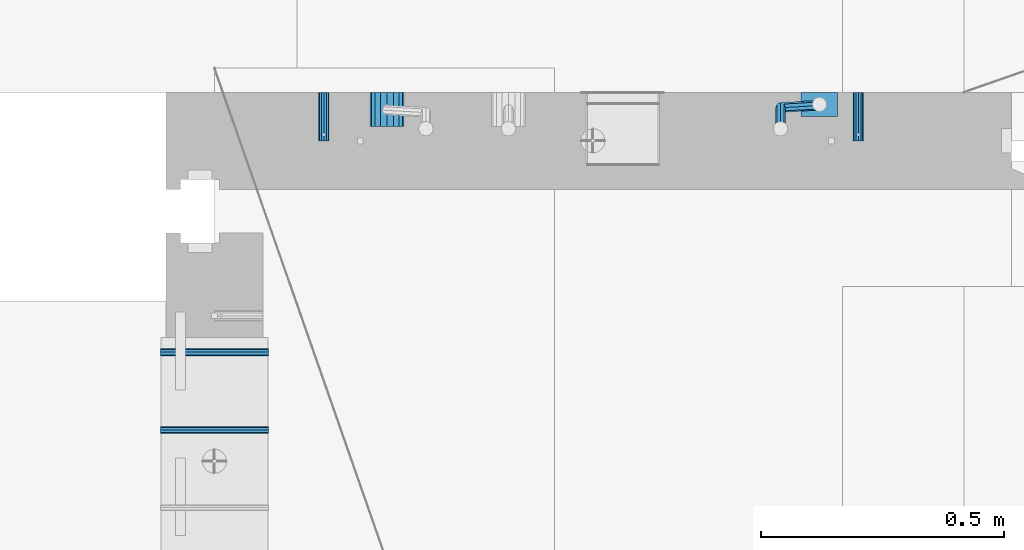
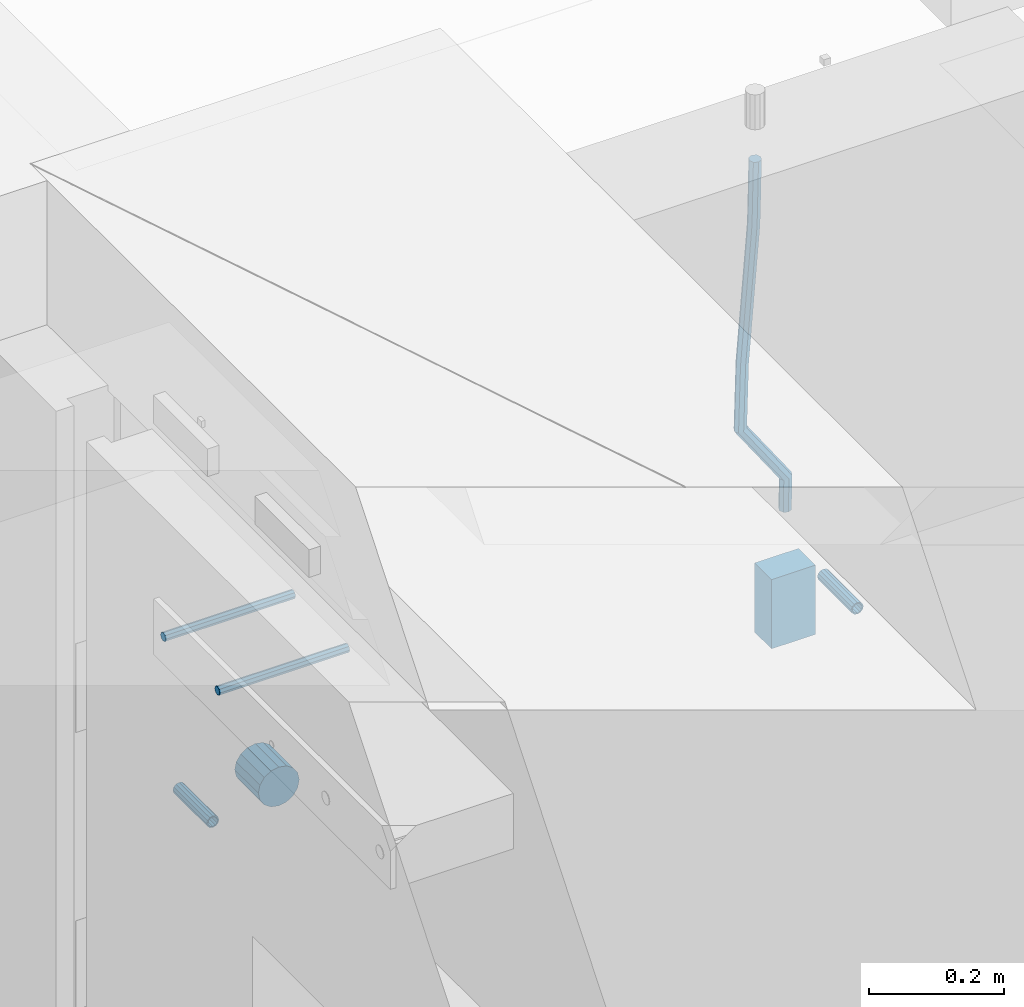
# One storey, part 138 of 309: 7 beams, 4 elements without a shape of their own.
"""IFC2X3 building model written with IfcOpenShell, lengths in millimetres."""

from ifc_helpers import new_model, si_unit, frame, origin_with_axes, place, context, subcontext, project, spatial, faceted_brep, material, type_object, element, aggregate, save


model = new_model("IFC2X3")

# Units and contexts
model_context = context("Model", 3, precision=1e-05, world=origin_with_axes())
body_context = subcontext(model_context, "Body", "Model", "MODEL_VIEW")
ifc_project = project(units=[si_unit("LENGTHUNIT", "METRE", prefix="MILLI"), si_unit("AREAUNIT", "SQUARE_METRE"), si_unit("VOLUMEUNIT", "CUBIC_METRE"), si_unit("MASSUNIT", "GRAM", prefix="KILO"), si_unit("TIMEUNIT", "SECOND"), si_unit("PLANEANGLEUNIT", "RADIAN"), si_unit("SOLIDANGLEUNIT", "STERADIAN"), si_unit("THERMODYNAMICTEMPERATUREUNIT", "DEGREE_CELSIUS"), si_unit("LUMINOUSINTENSITYUNIT", "LUMEN")], contexts=[model_context])

# Site, building, storey
site_placement = place(None, origin_with_axes())
site = spatial("IfcSite", under=ifc_project, at=site_placement, CompositionType="ELEMENT")
building_placement = place(site_placement, origin_with_axes())
building = spatial("IfcBuilding", under=site, at=building_placement, CompositionType="ELEMENT")
storey_placement = place(building_placement, origin_with_axes())
storey = spatial("IfcBuildingStorey", under=building, at=storey_placement, Name="7", CompositionType="ELEMENT", Elevation=0.0)

# Assemblies, beams
assembly_1_placement = place(storey_placement, origin_with_axes())
assembly_1 = element("IfcElementAssembly", 1, at=assembly_1_placement, inside=storey, AssemblyPlace="NOTDEFINED", PredefinedType="REINFORCEMENT_UNIT")
assembly_2_placement = place(assembly_1_placement, origin_with_axes())
assembly_2 = element("IfcElementAssembly", 2, at=assembly_2_placement, Name="Steel Assembly", AssemblyPlace="NOTDEFINED", PredefinedType="RIGID_FRAME")
ifc_material_1 = material(Name="STEEL/Steel_Undefined")
beam_type_1 = type_object("IfcBeamType", PredefinedType="NOTDEFINED")
beam_1_placement = place(assembly_2_placement, frame((27934.9999668009, 17080.0, 101555.0), z_axis=(1.0, 0.0, 0.0), x_axis=(0.0, -1.0, 0.0)))
beam_1 = element("IfcBeam", 3, at=beam_1_placement, type_object=beam_type_1, material=ifc_material_1, Name="M16", context=body_context, shape_type="Brep", body=[
    faceted_brep([(0.0, -8.49999999999272, -1.45519152283669e-11), (0.0, -7.36121593215648, 4.24999999998545), (100.000000000262, -7.36121593215648, 4.24999999998545), (100.000000000262, -8.49999999999272, -1.45519152283669e-11), (0.0, -4.24999999998545, 7.36121593216376), (100.000000000262, -4.24999999998545, 7.36121593216376), (0.0, 1.45519152283669e-11, 8.49999999998545), (100.000000000262, 1.45519152283669e-11, 8.49999999998545), (0.0, 4.25000000001455, 7.36121593216376), (100.000000000262, 4.25000000001455, 7.36121593216376), (0.0, 7.36121593217104, 4.24999999998545), (100.000000000262, 7.36121593217104, 4.24999999998545), (0.0, 8.50000000000728, 0.0), (100.000000000262, 8.50000000000728, 0.0), (0.0, 7.36121593217104, -4.25000000001455), (100.000000000262, 7.36121593217104, -4.25000000001455), (0.0, 4.25000000000728, -7.36121593219286), (100.000000000262, 4.25000000000728, -7.36121593219286), (0.0, 7.27595761418343e-12, -8.5), (100.000000000262, 7.27595761418343e-12, -8.5), (0.0, -4.24999999999272, -7.36121593217831), (100.000000000262, -4.24999999999272, -7.36121593217831), (0.0, -7.36121593215648, -4.25), (100.000000000262, -7.36121593215648, -4.25), (0.0, -10.4999999999927, -1.45519152283669e-11), (0.0, -9.09326673972828, -5.25000000001455), (100.000000000262, -9.09326673972828, -5.25000000001455), (100.000000000262, -10.4999999999927, -1.45519152283669e-11), (0.0, -5.24999999998545, -9.09326673974283), (100.000000000262, -5.24999999998545, -9.09326673974283), (0.0, 7.27595761418343e-12, -10.5), (100.000000000262, 7.27595761418343e-12, -10.5), (0.0, 5.25000000001455, -9.09326673975738), (100.000000000262, 5.25000000001455, -9.09326673975738), (0.0, 9.09326673975011, -5.25000000001455), (100.000000000262, 9.09326673975011, -5.25000000001455), (0.0, 10.5000000000073, -1.45519152283669e-11), (100.000000000262, 10.5000000000073, -1.45519152283669e-11), (0.0, 9.09326673975011, 5.25), (100.000000000262, 9.09326673975011, 5.25), (0.0, 5.25000000000728, 9.09326673972828), (100.000000000262, 5.25000000000728, 9.09326673972828), (0.0, 1.45519152283669e-11, 10.4999999999854), (100.000000000262, 1.45519152283669e-11, 10.4999999999854), (0.0, -5.24999999999272, 9.09326673972828), (100.000000000262, -5.24999999999272, 9.09326673972828), (0.0, -9.09326673972828, 5.24999999998545), (100.000000000262, -9.09326673972828, 5.24999999998545)], [[[0, 1, 2, 3]], [[1, 4, 5, 2]], [[4, 6, 7, 5]], [[6, 8, 9, 7]], [[8, 10, 11, 9]], [[10, 12, 13, 11]], [[12, 14, 15, 13]], [[14, 16, 17, 15]], [[16, 18, 19, 17]], [[18, 20, 21, 19]], [[20, 22, 23, 21]], [[22, 0, 3, 23]], [[24, 25, 26, 27]], [[25, 28, 29, 26]], [[28, 30, 31, 29]], [[30, 32, 33, 31]], [[32, 34, 35, 33]], [[34, 36, 37, 35]], [[36, 38, 39, 37]], [[38, 40, 41, 39]], [[40, 42, 43, 41]], [[42, 44, 45, 43]], [[44, 46, 47, 45]], [[46, 24, 27, 47]], [[29, 31, 33, 35, 37, 39, 41, 43, 45, 47, 27, 26], [5, 7, 9, 11, 13, 15, 17, 19, 21, 23, 3, 2]], [[46, 44, 42, 40, 38, 36, 34, 32, 30, 28, 25, 24], [22, 20, 18, 16, 14, 12, 10, 8, 6, 4, 1, 0]]]),
])
aggregate(assembly_2, [beam_1])
assembly_3_placement = place(assembly_1_placement, origin_with_axes())
assembly_3 = element("IfcElementAssembly", 4, at=assembly_3_placement, Name="Steel Assembly", AssemblyPlace="NOTDEFINED", PredefinedType="RIGID_FRAME")
beam_2_placement = place(assembly_3_placement, frame((26834.9999668009, 17080.0, 101555.0), z_axis=(-1.0, 3.00000001838171e-08, 0.0), x_axis=(0.0, -1.0, 0.0)))
beam_2 = element("IfcBeam", 5, at=beam_2_placement, type_object=beam_type_1, material=ifc_material_1, Name="M16", context=body_context, shape_type="Brep", body=[
    faceted_brep([(0.0, -8.49999999999272, -1.45519152283669e-11), (0.0, -7.36121593215648, 4.24999999998545), (100.000000000262, -7.36121593215648, 4.24999999998545), (100.000000000262, -8.49999999999272, -1.45519152283669e-11), (0.0, -4.24999999998545, 7.36121593216376), (100.000000000262, -4.24999999998545, 7.36121593216376), (0.0, 1.45519152283669e-11, 8.49999999998545), (100.000000000262, 1.45519152283669e-11, 8.49999999998545), (0.0, 4.25000000001455, 7.36121593216376), (100.000000000262, 4.25000000001455, 7.36121593216376), (0.0, 7.36121593217104, 4.24999999998545), (100.000000000262, 7.36121593217104, 4.24999999998545), (0.0, 8.50000000000728, 0.0), (100.000000000262, 8.50000000000728, 0.0), (0.0, 7.36121593217104, -4.25000000001455), (100.000000000262, 7.36121593217104, -4.25000000001455), (0.0, 4.25000000000728, -7.36121593219286), (100.000000000262, 4.25000000000728, -7.36121593219286), (0.0, 7.27595761418343e-12, -8.5), (100.000000000262, 7.27595761418343e-12, -8.5), (0.0, -4.24999999999272, -7.36121593217831), (100.000000000262, -4.24999999999272, -7.36121593217831), (0.0, -7.36121593215648, -4.25), (100.000000000262, -7.36121593215648, -4.25), (0.0, -10.4999999999927, -1.45519152283669e-11), (0.0, -9.09326673972828, -5.25000000001455), (100.000000000262, -9.09326673972828, -5.25000000001455), (100.000000000262, -10.4999999999927, -1.45519152283669e-11), (0.0, -5.24999999998545, -9.09326673974283), (100.000000000262, -5.24999999998545, -9.09326673974283), (0.0, 7.27595761418343e-12, -10.5), (100.000000000262, 7.27595761418343e-12, -10.5), (0.0, 5.25000000001455, -9.09326673975738), (100.000000000262, 5.25000000001455, -9.09326673975738), (0.0, 9.09326673975011, -5.25000000001455), (100.000000000262, 9.09326673975011, -5.25000000001455), (0.0, 10.5000000000073, -1.45519152283669e-11), (100.000000000262, 10.5000000000073, -1.45519152283669e-11), (0.0, 9.09326673975011, 5.25), (100.000000000262, 9.09326673975011, 5.25), (0.0, 5.25000000000728, 9.09326673972828), (100.000000000262, 5.25000000000728, 9.09326673972828), (0.0, 1.45519152283669e-11, 10.4999999999854), (100.000000000262, 1.45519152283669e-11, 10.4999999999854), (0.0, -5.24999999999272, 9.09326673972828), (100.000000000262, -5.24999999999272, 9.09326673972828), (0.0, -9.09326673972828, 5.24999999998545), (100.000000000262, -9.09326673972828, 5.24999999998545)], [[[0, 1, 2, 3]], [[1, 4, 5, 2]], [[4, 6, 7, 5]], [[6, 8, 9, 7]], [[8, 10, 11, 9]], [[10, 12, 13, 11]], [[12, 14, 15, 13]], [[14, 16, 17, 15]], [[16, 18, 19, 17]], [[18, 20, 21, 19]], [[20, 22, 23, 21]], [[22, 0, 3, 23]], [[24, 25, 26, 27]], [[25, 28, 29, 26]], [[28, 30, 31, 29]], [[30, 32, 33, 31]], [[32, 34, 35, 33]], [[34, 36, 37, 35]], [[36, 38, 39, 37]], [[38, 40, 41, 39]], [[40, 42, 43, 41]], [[42, 44, 45, 43]], [[44, 46, 47, 45]], [[46, 24, 27, 47]], [[29, 31, 33, 35, 37, 39, 41, 43, 45, 47, 27, 26], [5, 7, 9, 11, 13, 15, 17, 19, 21, 23, 3, 2]], [[46, 44, 42, 40, 38, 36, 34, 32, 30, 28, 25, 24], [22, 20, 18, 16, 14, 12, 10, 8, 6, 4, 1, 0]]]),
])
aggregate(assembly_3, [beam_2])
ifc_material_2 = material()
beam_type_2 = type_object("IfcBeamType", Name="D20", PredefinedType="NOTDEFINED")
beam_3_placement = place(assembly_1_placement, frame((27854.9999105249, 17055.0000022791, 101717.5), z_axis=(0.00020576299992186, -0.999642804629538, -0.0267249099901004), x_axis=(-4.30000201928125e-08, -0.0267249099948059, 0.999642825806181)))
beam_3 = element("IfcBeam", 6, at=beam_3_placement, type_object=beam_type_2, material=ifc_material_2, Name="JM20", ObjectType="D20", context=body_context, shape_type="Brep", body=[
    faceted_brep([(0.0, -10.0, 0.0), (-4.19531716033816e-08, -7.07106781186667, -7.07106781187031), (57.3778003524785, -7.07106779628884, -7.0710678060168), (57.3778003565822, -9.99999998442945, 5.84986992180347e-09), (0.0, 0.0, -10.0), (57.3778003491898, 1.55741872731596e-08, -9.99999999415013), (4.196772351861e-08, 7.07106781186303, -7.07106781186667), (57.3778003486368, 7.07106782744086, -7.0710678060168), (0.0, 10.0, 0.0), (57.3778003511543, 10.0000000155705, 5.84986992180347e-09), (4.196772351861e-08, 7.07106781185939, 7.07106781185939), (57.3778003552725, 7.07106782744086, 7.0710678177129), (0.0, 0.0, 10.0), (57.3778003585467, 1.55741872731596e-08, 10.0000000058535), (-4.19531716033816e-08, -7.07106781187031, 7.07106781185939), (57.3778003591142, -7.07106779628884, 7.0710678177129), (63.2348501311644, -7.07106779493188, -7.07106780540926), (64.1057957623998, -9.99999998283238, 6.54472387395799e-09), (61.04994790192, 1.63490767590702e-08, -9.99999999377178), (58.8309751681372, 7.07106782761548, -7.07106780586037), (57.8777760627127, 10.0000000155014, 5.90807758271694e-09), (58.7487216939626, 7.07106782759729, 7.07106781786206), (60.9336239231925, 1.63163349498063e-08, 10.0000000062173), (63.1525966569752, -7.07106779495371, 7.07106781830953), (68.0560815638019, -3.74583294561307, -7.00896065082998), (69.6439432500047, -6.18030344188082, 0.0713424813729944), (64.0726841869619, 2.08480100043016, -9.96106107280502), (60.0271712784888, 7.89609210789058, -7.05565839484916), (58.2893494334276, 10.283864860914, 0.00530189843993867), (59.8772111196158, 7.84939436464629, 7.08560503063927), (63.8606084964704, 2.01876041860305, 10.037705452618), (67.9061214049289, -3.79253068885737, 7.13230277466573), (178.098456601496, 72.1511127806843, -5.59139360533663), (179.686318287684, 69.716642284413, 1.48890952685906), (174.115059224641, 77.9817467267239, -8.54349402731532), (170.069546316168, 83.7930378341844, -5.63809134935946), (168.331724471092, 86.1808105872078, 1.42286894392964), (169.91958615731, 83.7463400909437, 8.50317207612898), (173.90298353415, 77.9157061448968, 11.455272498104), (177.948496442623, 72.1044150374437, 8.5498698201518), (179.289255982527, 72.9724149014583, -5.57605371504542), (180.097891658399, 70.0005071298292, 1.4942114193982), (177.129995245661, 80.0611678177193, -8.50465558942597), (174.884975102759, 87.1142705605816, -5.5760589445199), (173.869297905752, 90.00011120009, 1.49420402380565), (174.67793358161, 87.0282034284573, 8.5644691582529), (176.837194318476, 79.9394505121963, 11.4930710326298), (179.082214461378, 72.8863477693376, 8.56447438772739), (180.735622590379, 72.972420835973, -5.54778204405011), (180.597796167538, 70.0005091809617, 1.50398289485383), (180.791991426609, 80.0611828430738, -8.4330757073476), (180.733882576489, 87.1142945589418, -5.46173219850607), (180.595335416292, 90.0001387973534, 1.62567575346111), (180.457508993451, 87.0282271423457, 8.67744069236505), (180.401140157206, 79.939465135245, 11.5627343556625), (180.459249007356, 72.8863534193733, 8.59139084682101), (299.223827734662, 72.9729069989553, -3.23173054285144), (299.086001311836, 70.0009953439476, 3.82003439605251), (299.280196570893, 80.0616690060597, -6.11702420615256), (299.222087720773, 87.1147807219277, -3.14568069731467), (299.083540560576, 90.0006249603393, 3.94172725465251), (298.945714137735, 87.0287133053316, 10.9934921935564), (298.889345301504, 79.9399512982272, 13.8787858568576), (298.947454151639, 72.8868395823556, 10.9074423480197), (300.386274806908, 72.9729117685347, -3.20900855728542), (299.975441269635, 70.0009989933678, 3.8374199978316), (300.554299891708, 80.0616742337661, -6.09211971118202), (300.381089708186, 87.1147854773699, -3.12302605173682), (299.968108432717, 90.0006285897653, 3.95901762330686), (299.557274895458, 87.0287158145948, 11.0054461784239), (299.389249810658, 79.9399533493597, 13.8885573323169), (299.562459994166, 72.8868421057559, 10.9194636728716), (301.54348499664, 72.972935138263, -3.09647384826167), (300.860874255726, 70.0010168745794, 3.92352530897551), (301.822663312996, 80.0616998482183, -5.96877573286474), (301.534870333402, 87.1148087778347, -3.01082485606094), (300.848691282124, 90.0006463730351, 4.04465127535514), (300.166080541225, 87.0287281093551, 11.0646504325923), (299.886902224855, 79.9399633993926, 13.9369523171918), (300.174695204449, 72.8868544697798, 10.9790014403879), (567.277632096637, 72.9783016087349, 22.7452575737989), (566.595021355723, 70.0063833450513, 29.7652567310361), (567.556810412992, 80.0670663186975, 19.8729556891958), (567.269017433413, 87.1201752483139, 22.8309065659996), (566.582838382135, 90.0060128435071, 29.886382697412), (565.900227641221, 87.0340945798234, 36.9063818546456), (565.621049324851, 79.9453298698681, 39.7786837392523), (565.90884230446, 72.8922209402554, 36.8207328624449), (567.849310941645, 72.9783131537188, 22.8008513743443), (567.441064932689, 70.0064004308078, 29.8475315576834), (568.054462827218, 80.0670763687303, 19.9213506740707), (567.93634539716, 87.1201887249226, 22.8958019142228), (567.564150240039, 90.0060326609891, 29.9818118989315), (567.155904231084, 87.0341199380709, 37.0284920822669), (566.950752345525, 79.9453567230667, 39.9079927825405), (567.068869775569, 72.8922443668707, 36.9335415423957), (568.423586898687, 72.9708243880268, 22.8084944200891), (568.290952048657, 69.9953175961527, 29.8588427157192), (568.554376054599, 80.0605573198627, 19.9280040253361), (568.606705002705, 87.1114469937784, 22.9047237384184), (568.549920154881, 89.9931778656028, 29.9949315228005), (568.417285304851, 87.0176710737251, 37.0452798184269), (568.286496148939, 79.9279381418964, 39.9257702131799), (568.234167200833, 72.8770484679771, 36.9490505000977), (589.912124239258, 72.6906061074042, 23.0944856267633), (589.779489389242, 69.7150993155265, 30.1448339223862), (590.042913395198, 79.7803390392328, 20.2139952320067), (590.095242343275, 86.8312287131521, 23.190714945089), (590.038457495451, 89.7129595849765, 30.2809227294711), (589.905822645451, 86.7374527930988, 37.3312710250975), (589.775033489525, 79.6477198612702, 40.2117614198505), (589.722704541418, 72.5968301873472, 37.2350417067682), (590.547165551296, 72.6823249395493, 23.1029373993588), (590.439554471668, 69.7064918286778, 30.1536187366546), (590.620682129796, 79.7728047264573, 20.2216847631717), (590.617039192599, 86.8244242939545, 23.197659545749), (590.538370722847, 89.7064405361089, 30.2875760807365), (590.430759643248, 86.7306074252338, 37.3382574180287), (590.357243064718, 79.6401276383258, 40.2195100542194), (590.36088600193, 72.5885080708285, 37.243535271642), (591.182260594243, 72.6841934809891, 23.1112002334121), (591.099675200006, 69.7084600799535, 30.1622167658497), (591.198500084778, 79.7744922147613, 20.2291794306657), (591.138880798317, 86.8259554442993, 23.2044030568104), (591.038326904265, 89.7079316443269, 30.2940254627501), (590.955741510043, 86.7321982432914, 37.3450419951805), (590.939502019522, 79.6418995095191, 40.2270627979342), (590.999121305984, 72.5904362799774, 37.2518391717822), (691.203058405095, 72.9824563748625, 24.4085746238379), (691.120473010888, 70.0067229738306, 31.4595911562756), (691.219297895645, 80.0727551086347, 21.5265538210951), (691.159678609169, 87.1242183381728, 24.5017774472362), (691.059124715146, 90.0061945381967, 31.591399853176), (690.976539320895, 87.0304611371721, 38.6424163856136), (690.960299830374, 79.9401624033926, 41.5244371883564), (691.019919116836, 72.8886991738545, 38.5492135622153)], [[[0, 1, 2, 3]], [[1, 4, 5, 2]], [[4, 6, 7, 5]], [[6, 8, 9, 7]], [[8, 10, 11, 9]], [[10, 12, 13, 11]], [[12, 14, 15, 13]], [[14, 0, 3, 15]], [[14, 12, 10, 8, 6, 4, 1, 0]], [[3, 2, 16, 17]], [[2, 5, 18, 16]], [[5, 7, 19, 18]], [[7, 9, 20, 19]], [[9, 11, 21, 20]], [[11, 13, 22, 21]], [[13, 15, 23, 22]], [[15, 3, 17, 23]], [[17, 16, 24, 25]], [[16, 18, 26, 24]], [[18, 19, 27, 26]], [[19, 20, 28, 27]], [[20, 21, 29, 28]], [[21, 22, 30, 29]], [[22, 23, 31, 30]], [[23, 17, 25, 31]], [[25, 24, 32, 33]], [[24, 26, 34, 32]], [[26, 27, 35, 34]], [[27, 28, 36, 35]], [[28, 29, 37, 36]], [[29, 30, 38, 37]], [[30, 31, 39, 38]], [[31, 25, 33, 39]], [[33, 32, 40, 41]], [[32, 34, 42, 40]], [[34, 35, 43, 42]], [[35, 36, 44, 43]], [[36, 37, 45, 44]], [[37, 38, 46, 45]], [[38, 39, 47, 46]], [[39, 33, 41, 47]], [[41, 40, 48, 49]], [[40, 42, 50, 48]], [[42, 43, 51, 50]], [[43, 44, 52, 51]], [[44, 45, 53, 52]], [[45, 46, 54, 53]], [[46, 47, 55, 54]], [[47, 41, 49, 55]], [[49, 48, 56, 57]], [[48, 50, 58, 56]], [[50, 51, 59, 58]], [[51, 52, 60, 59]], [[52, 53, 61, 60]], [[53, 54, 62, 61]], [[54, 55, 63, 62]], [[55, 49, 57, 63]], [[57, 56, 64, 65]], [[56, 58, 66, 64]], [[58, 59, 67, 66]], [[59, 60, 68, 67]], [[60, 61, 69, 68]], [[61, 62, 70, 69]], [[62, 63, 71, 70]], [[63, 57, 65, 71]], [[65, 64, 72, 73]], [[64, 66, 74, 72]], [[66, 67, 75, 74]], [[67, 68, 76, 75]], [[68, 69, 77, 76]], [[69, 70, 78, 77]], [[70, 71, 79, 78]], [[71, 65, 73, 79]], [[73, 72, 80, 81]], [[72, 74, 82, 80]], [[74, 75, 83, 82]], [[75, 76, 84, 83]], [[76, 77, 85, 84]], [[77, 78, 86, 85]], [[78, 79, 87, 86]], [[79, 73, 81, 87]], [[81, 80, 88, 89]], [[80, 82, 90, 88]], [[82, 83, 91, 90]], [[83, 84, 92, 91]], [[84, 85, 93, 92]], [[85, 86, 94, 93]], [[86, 87, 95, 94]], [[87, 81, 89, 95]], [[89, 88, 96, 97]], [[88, 90, 98, 96]], [[90, 91, 99, 98]], [[91, 92, 100, 99]], [[92, 93, 101, 100]], [[93, 94, 102, 101]], [[94, 95, 103, 102]], [[95, 89, 97, 103]], [[97, 96, 104, 105]], [[96, 98, 106, 104]], [[98, 99, 107, 106]], [[99, 100, 108, 107]], [[100, 101, 109, 108]], [[101, 102, 110, 109]], [[102, 103, 111, 110]], [[103, 97, 105, 111]], [[105, 104, 112, 113]], [[104, 106, 114, 112]], [[106, 107, 115, 114]], [[107, 108, 116, 115]], [[108, 109, 117, 116]], [[109, 110, 118, 117]], [[110, 111, 119, 118]], [[111, 105, 113, 119]], [[113, 112, 120, 121]], [[112, 114, 122, 120]], [[114, 115, 123, 122]], [[115, 116, 124, 123]], [[116, 117, 125, 124]], [[117, 118, 126, 125]], [[118, 119, 127, 126]], [[119, 113, 121, 127]], [[121, 120, 128, 129]], [[120, 122, 130, 128]], [[122, 123, 131, 130]], [[123, 124, 132, 131]], [[124, 125, 133, 132]], [[125, 126, 134, 133]], [[126, 127, 135, 134]], [[127, 121, 129, 135]], [[130, 131, 132, 133, 134, 135, 129, 128]]]),
])
beam_type_3 = type_object("IfcBeamType", Name="D70", PredefinedType="NOTDEFINED")
beam_4_placement = place(assembly_1_placement, frame((26964.9999105288, 17080.0000022791, 101555.0), z_axis=(0.0, 0.0, 1.0), x_axis=(0.0, -1.0, 0.0)))
beam_4 = element("IfcBeam", 7, at=beam_4_placement, type_object=beam_type_3, material=ifc_material_2, ObjectType="D70", context=body_context, shape_type="Brep", body=[
    faceted_brep([(0.0, -35.0, 0.0), (0.0, -32.3357836378964, -13.3939201327739), (70.0, -32.3357836378964, -13.3939201327739), (70.0, -35.0, 0.0), (0.0, -24.7487373415279, -24.7487373415352), (70.0, -24.7487373415279, -24.7487373415352), (0.0, -13.3939201327776, -32.3357836379), (70.0, -13.3939201327776, -32.3357836379), (0.0, 0.0, -35.0), (70.0, 0.0, -35.0), (0.0, 13.3939201327776, -32.3357836379), (70.0, 13.3939201327776, -32.3357836379), (0.0, 24.7487373415279, -24.7487373415352), (70.0, 24.7487373415279, -24.7487373415352), (0.0, 32.3357836378964, -13.3939201327739), (70.0, 32.3357836378964, -13.3939201327739), (0.0, 35.0, 0.0), (70.0, 35.0, 0.0), (0.0, 32.3357836378964, 13.3939201327739), (70.0, 32.3357836378964, 13.3939201327739), (0.0, 24.7487373415279, 24.7487373415352), (70.0, 24.7487373415279, 24.7487373415352), (0.0, 13.3939201327776, 32.3357836379), (70.0, 13.3939201327776, 32.3357836379), (0.0, 0.0, 35.0), (70.0, 0.0, 35.0), (0.0, -13.3939201327776, 32.3357836379), (70.0, -13.3939201327776, 32.3357836379), (0.0, -24.7487373415279, 24.7487373415352), (70.0, -24.7487373415279, 24.7487373415352), (0.0, -32.3357836378964, 13.3939201327739), (70.0, -32.3357836378964, 13.3939201327739)], [[[0, 1, 2, 3]], [[1, 4, 5, 2]], [[4, 6, 7, 5]], [[6, 8, 9, 7]], [[8, 10, 11, 9]], [[10, 12, 13, 11]], [[12, 14, 15, 13]], [[14, 16, 17, 15]], [[16, 18, 19, 17]], [[18, 20, 21, 19]], [[20, 22, 23, 21]], [[22, 24, 25, 23]], [[24, 26, 27, 25]], [[26, 28, 29, 27]], [[28, 30, 31, 29]], [[30, 0, 3, 31]], [[5, 7, 9, 11, 13, 15, 17, 19, 21, 23, 25, 27, 29, 31, 3, 2]], [[30, 28, 26, 24, 22, 20, 18, 16, 14, 12, 10, 8, 6, 4, 1, 0]]]),
])

# Assembly, beams
assembly_4_placement = place(storey_placement, origin_with_axes())
assembly_4 = element("IfcElementAssembly", 8, at=assembly_4_placement, inside=storey, AssemblyPlace="NOTDEFINED", PredefinedType="REINFORCEMENT_UNIT")
ifc_material_3 = material()
beam_type_4 = type_object("IfcBeamType", Name="D15", PredefinedType="NOTDEFINED")
beam_5_placement = place(assembly_4_placement, frame((26720.9994161083, 16544.9998474121, 102270.0), z_axis=(0.0, -1.0, 0.0), x_axis=(-1.0, 3.00000001838171e-08, 0.0)))
beam_5 = element("IfcBeam", 9, at=beam_5_placement, type_object=beam_type_4, material=ifc_material_3, Name="15", ObjectType="D15", context=body_context, shape_type="Brep", body=[
    faceted_brep([(0.0, -7.5, 0.0), (0.0, -5.30330085889727, -5.30330085890091), (222.000077784061, -5.30330085889727, -5.30330085890091), (222.000077784061, -7.5, 0.0), (0.0, 1.45519152283669e-11, -7.5), (222.000077784061, 0.0, -7.5), (0.0, 5.30330085889727, -5.30330085890091), (222.000077784061, 5.30330085889727, -5.30330085890091), (0.0, 7.5, 0.0), (222.000077784061, 7.5, 0.0), (0.0, 5.30330085889727, 5.30330085890091), (222.000077784061, 5.30330085889727, 5.30330085890091), (0.0, 1.45519152283669e-11, 7.5), (222.000077784061, 0.0, 7.5), (0.0, -5.30330085889727, 5.30330085890091), (222.000077784061, -5.30330085889727, 5.30330085890091)], [[[0, 1, 2, 3]], [[1, 4, 5, 2]], [[4, 6, 7, 5]], [[6, 8, 9, 7]], [[8, 10, 11, 9]], [[10, 12, 13, 11]], [[12, 14, 15, 13]], [[14, 0, 3, 15]], [[5, 7, 9, 11, 13, 15, 3, 2]], [[14, 12, 10, 8, 6, 4, 1, 0]]]),
])
beam_6_placement = place(assembly_4_placement, frame((26720.9994161083, 16385.0, 102270.0), z_axis=(0.0, -1.0, 0.0), x_axis=(-1.0, 3.00000001838171e-08, 0.0)))
beam_6 = element("IfcBeam", 10, at=beam_6_placement, type_object=beam_type_4, material=ifc_material_3, Name="15", ObjectType="D15", context=body_context, shape_type="Brep", body=[
    faceted_brep([(0.0, -7.5, 0.0), (0.0, -5.30330085889727, -5.30330085890091), (222.000077784061, -5.30330085889727, -5.30330085890091), (222.000077784061, -7.5, 0.0), (0.0, 1.45519152283669e-11, -7.5), (222.000077784061, 0.0, -7.5), (0.0, 5.30330085889727, -5.30330085890091), (222.000077784061, 5.30330085889727, -5.30330085890091), (0.0, 7.5, 0.0), (222.000077784061, 7.5, 0.0), (0.0, 5.30330085889727, 5.30330085890091), (222.000077784061, 5.30330085889727, 5.30330085890091), (0.0, 1.45519152283669e-11, 7.5), (222.000077784061, 0.0, 7.5), (0.0, -5.30330085889727, 5.30330085890091), (222.000077784061, -5.30330085889727, 5.30330085890091)], [[[0, 1, 2, 3]], [[1, 4, 5, 2]], [[4, 6, 7, 5]], [[6, 8, 9, 7]], [[8, 10, 11, 9]], [[10, 12, 13, 11]], [[12, 14, 15, 13]], [[14, 0, 3, 15]], [[5, 7, 9, 11, 13, 15, 3, 2]], [[14, 12, 10, 8, 6, 4, 1, 0]]]),
])
aggregate(assembly_4, [beam_5, beam_6])

# Beam
beam_type_5 = type_object("IfcBeamType", PredefinedType="NOTDEFINED")
beam_7_placement = place(assembly_1_placement, frame((27892.4999105288, 17055.0, 101555.0), z_axis=(0.0, 0.0, 1.0), x_axis=(-1.0, 3.00000001838171e-08, 0.0)))
beam_7 = element("IfcBeam", 11, at=beam_7_placement, type_object=beam_type_5, material=ifc_material_2, Name="WM1", context=body_context, shape_type="Brep", body=[
    faceted_brep([(0.0, 25.0, -62.5), (0.0, 25.0, 62.5), (75.0, 25.0, 62.5), (75.0, 25.0, -62.5), (0.0, -25.0, 62.5), (75.0, -25.0, 62.5), (0.0, -25.0, -62.5), (75.0, -25.0, -62.5)], [[[0, 1, 2, 3]], [[1, 4, 5, 2]], [[4, 6, 7, 5]], [[6, 0, 3, 7]], [[5, 7, 3, 2]], [[0, 6, 4, 1]]]),
])

aggregate(assembly_1, [assembly_2, assembly_3, beam_3, beam_7, beam_4])

save(model, "model.ifc")
